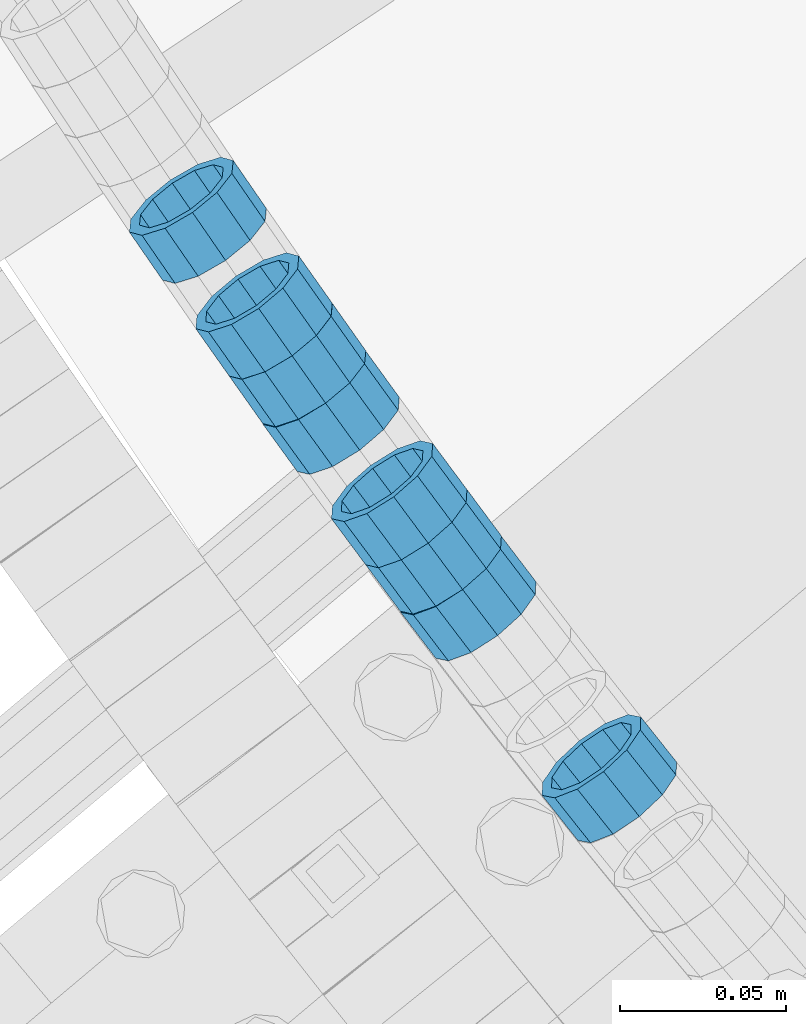
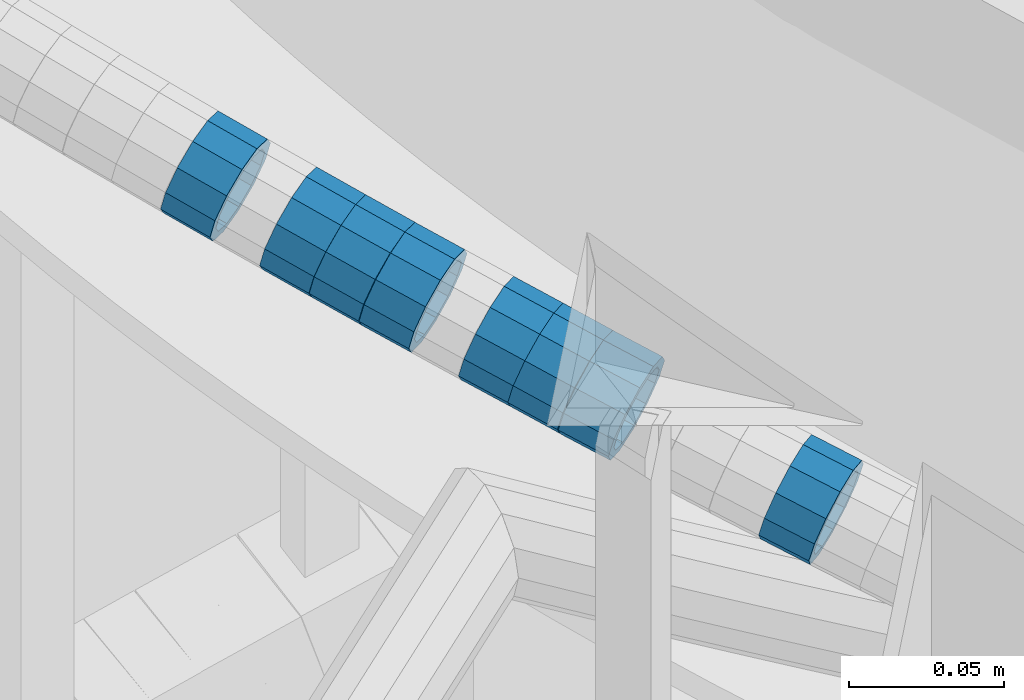
# One storey, part 652 of 975: 8 beams.
"""IFC2X3 building model written with IfcOpenShell, lengths in millimetres."""

import ifcopenshell
import ifcopenshell.guid

model = None  # the IFC model being written
_history = None  # IfcOwnerHistory: only IFC2X3 demands one
_inside = {}  # id of a spatial element -> (the spatial element, [elements in it])
_under = {}  # id of a project, library or spatial element -> (it, [spatial elements below it])
_declared = {}  # id of a project -> (the project, [libraries it declares])
_typed = {}  # id of a type object -> (the type object, [elements of that type])
_made_of = {}  # id of a material, layer set ... -> (it, [elements and type objects made of it])


def new_model(schema):
    """Start an empty IFC model of exactly this schema.

    Asked for "IFC4X3", IfcOpenShell would pick the latest addendum, in which some entities
    have other attributes; the version numbers below select the first issue.
    IFC2X3 requires an IfcOwnerHistory on every rooted entity: one is made here for all.
    """
    global model, _history
    if schema == "IFC4X3":
        model = ifcopenshell.file(schema_version=(4, 3, 0, 0))
    else:
        model = ifcopenshell.file(schema=schema)
    _inside.clear()
    _under.clear()
    _declared.clear()
    _typed.clear()
    _made_of.clear()
    _history = None
    if model.schema == "IFC2X3":
        org = make("IfcOrganization", Name="unknown")
        user = make(
            "IfcPersonAndOrganization",
            ThePerson=make("IfcPerson", FamilyName="unknown"),
            TheOrganization=org,
        )
        app = make(
            "IfcApplication",
            ApplicationDeveloper=org,
            Version="unknown",
            ApplicationFullName="unknown",
            ApplicationIdentifier="unknown",
        )
        _history = make(
            "IfcOwnerHistory",
            OwningUser=user,
            OwningApplication=app,
            ChangeAction="ADDED",
            CreationDate=0,
        )
    return model


def make(cls, **values):
    """One entity of the class cls with the attributes given. An attribute that is None is left unset."""
    return model.create_entity(
        cls, **{name: value for name, value in values.items() if value is not None}
    )


def rooted(cls, **values):
    """An entity with a GlobalId (a new one), such as an element, a storey or a relation."""
    return make(cls, GlobalId=ifcopenshell.guid.new(), OwnerHistory=_history, **values)


def si_unit(unit_type, name, prefix=None):
    """IfcSIUnit, for example si_unit("LENGTHUNIT", "METRE", prefix="MILLI")."""
    return make("IfcSIUnit", UnitType=unit_type, Prefix=prefix, Name=name)


def assignment(units):
    """IfcUnitAssignment: the units of a project."""
    return None if units is None else make("IfcUnitAssignment", Units=units)


def point(xyz):
    """IfcCartesianPoint."""
    return None if xyz is None else make("IfcCartesianPoint", Coordinates=xyz)


def direction(xyz):
    """IfcDirection."""
    return None if xyz is None else make("IfcDirection", DirectionRatios=xyz)


def frame(location, z_axis=None, x_axis=None):
    """IfcAxis2Placement3D, a coordinate frame: its origin and axes. An axis left out is left unset."""
    return make(
        "IfcAxis2Placement3D",
        Location=point(location),
        Axis=direction(z_axis),
        RefDirection=direction(x_axis),
    )


def origin_with_axes():
    """The frame at (0, 0, 0) with the z axis (0, 0, 1) and the x axis (1, 0, 0) written out."""
    return frame((0.0, 0.0, 0.0), z_axis=(0.0, 0.0, 1.0), x_axis=(1.0, 0.0, 0.0))


def place(relative_to, where):
    """IfcLocalPlacement: puts the frame where relative to a parent placement (None: the world)."""
    return make(
        "IfcLocalPlacement", PlacementRelTo=relative_to, RelativePlacement=where
    )


def context(
    kind, dimensions, precision=None, world=None, true_north=None, identifier=None
):
    """IfcGeometricRepresentationContext, for example the 3D "Model" context."""
    return make(
        "IfcGeometricRepresentationContext",
        ContextIdentifier=identifier,
        ContextType=kind,
        CoordinateSpaceDimension=dimensions,
        Precision=precision,
        WorldCoordinateSystem=world,
        TrueNorth=true_north,
    )


def subcontext(parent, identifier, kind, view, scale=None):
    """IfcGeometricRepresentationSubContext, for example "Body" below "Model"."""
    return make(
        "IfcGeometricRepresentationSubContext",
        ContextIdentifier=identifier,
        ContextType=kind,
        ParentContext=parent,
        TargetScale=scale,
        TargetView=view,
    )


def project(units=None, contexts=None):
    """IfcProject with its units and contexts."""
    return rooted(
        "IfcProject",
        Name="project",
        RepresentationContexts=contexts,
        UnitsInContext=assignment(units),
    )


def spatial(cls, under=None, at=None, **own):
    """A site, building, storey or space (cls), placed at a placement, below another one or the project."""
    s = rooted(cls, ObjectPlacement=at, **own)
    if under is not None:
        _under.setdefault(under.id(), (under, []))[1].append(s)
    return s


def faces_of(points, faces, orient=None, outer=None):
    """IfcFace entities. A face is a list of loops; a loop is a list of indices into points, from 0.

    orient and outer hold one flag for each loop. By default every Orientation is true, the
    first loop of a face is its IfcFaceOuterBound and the others are IfcFaceBound.
    """
    made = []
    for i, loops in enumerate(faces):
        bounds = []
        for j, loop in enumerate(loops):
            is_outer = j == 0 if outer is None else outer[i][j]
            bounds.append(
                make(
                    "IfcFaceOuterBound" if is_outer else "IfcFaceBound",
                    Bound=make("IfcPolyLoop", Polygon=[points[k] for k in loop]),
                    Orientation=True if orient is None else orient[i][j],
                )
            )
        made.append(make("IfcFace", Bounds=bounds))
    return made


def faceted_brep(points, faces, orient=None, outer=None, voids=None):
    """IfcFacetedBrep: a solid bounded by flat faces; with voids (closed shells), ...WithVoids."""
    shared = [point(p) for p in points]
    hull = make("IfcClosedShell", CfsFaces=faces_of(shared, faces, orient, outer))
    if voids is None:
        return make("IfcFacetedBrep", Outer=hull)
    return make(
        "IfcFacetedBrepWithVoids",
        Outer=hull,
        Voids=[
            make(cls, CfsFaces=faces_of(shared, fs, o, b)) for cls, fs, o, b in voids
        ],
    )


def shape(context_of_items, identifier, shape_type, items):
    """IfcShapeRepresentation: the items that make up one representation, for example the "Body"."""
    return make(
        "IfcShapeRepresentation",
        ContextOfItems=context_of_items,
        RepresentationIdentifier=identifier,
        RepresentationType=shape_type,
        Items=items,
    )


def material(Name=None, Category=None):
    """IfcMaterial."""
    return make("IfcMaterial", Name=Name, Category=Category)


def made_of(thing, what):
    """Note that an element or type object is made of a material, layer set ...; save() writes the relation."""
    if what is not None:
        _made_of.setdefault(what.id(), (what, []))[1].append(thing)
    return thing


def type_object(cls, material=None, **own):
    """A type object (cls), such as IfcWallType, which elements share."""
    return made_of(rooted(cls, **own), material)


def element(
    cls,
    number,
    at=None,
    inside=None,
    cuts=None,
    type_object=None,
    material=None,
    context=None,
    identifier="Body",
    shape_type=None,
    held_by="IfcProductDefinitionShape",
    body=None,
    shapes=None,
    **own,
):
    """One element of the class cls, such as IfcWall. Its Tag is "e" and its number.

    at: its placement. inside: the storey or other place that contains it. cuts: it is an
    opening in that element (IfcRelVoidsElement). A single representation is given by context,
    identifier, shape_type and body (its items); several are given by shapes. held_by: the class
    of the entity that holds the representations. save() writes the other relations.
    """
    e = rooted(cls, Tag="e%d" % number, ObjectPlacement=at, **own)
    if body is not None:
        shapes = [shape(context, identifier, shape_type, body)]
    if shapes is not None:
        e.Representation = make(held_by, Representations=shapes)
    if inside is not None:
        _inside.setdefault(inside.id(), (inside, []))[1].append(e)
    if cuts is not None:
        rooted(
            "IfcRelVoidsElement", RelatingBuildingElement=cuts, RelatedOpeningElement=e
        )
    if type_object is not None:
        _typed.setdefault(type_object.id(), (type_object, []))[1].append(e)
    return made_of(e, material)


def aggregate(whole, parts):
    """IfcRelAggregates: a whole, such as a stair, and the parts it consists of."""
    return rooted("IfcRelAggregates", RelatingObject=whole, RelatedObjects=parts)


def save(model, path):
    """Write the relations noted so far, then the file.

    IfcRelAggregates (storeys below a building ...), IfcRelContainedInSpatialStructure (elements
    in a storey), IfcRelDefinesByType, IfcRelAssociatesMaterial and IfcRelDeclares: one each for
    every whole, place, type object, material and project.
    """
    for whole, parts in _under.values():
        aggregate(whole, parts)
    for where, things in _inside.values():
        rooted(
            "IfcRelContainedInSpatialStructure",
            RelatedElements=things,
            RelatingStructure=where,
        )
    for kind, things in _typed.values():
        rooted("IfcRelDefinesByType", RelatedObjects=things, RelatingType=kind)
    for what, things in _made_of.values():
        rooted("IfcRelAssociatesMaterial", RelatedObjects=things, RelatingMaterial=what)
    for by, libraries in _declared.values():
        rooted("IfcRelDeclares", RelatingContext=by, RelatedDefinitions=libraries)
    model.write(path)


model = new_model("IFC2X3")

# Units and contexts
model_context = context("Model", 3, precision=1e-05, world=origin_with_axes())
body_context = subcontext(model_context, "Body", "Model", "MODEL_VIEW")
ifc_project = project(units=[si_unit("LENGTHUNIT", "METRE", prefix="MILLI"), si_unit("AREAUNIT", "SQUARE_METRE"), si_unit("VOLUMEUNIT", "CUBIC_METRE"), si_unit("MASSUNIT", "GRAM", prefix="KILO"), si_unit("TIMEUNIT", "SECOND"), si_unit("PLANEANGLEUNIT", "RADIAN"), si_unit("SOLIDANGLEUNIT", "STERADIAN"), si_unit("THERMODYNAMICTEMPERATUREUNIT", "DEGREE_CELSIUS"), si_unit("LUMINOUSINTENSITYUNIT", "LUMEN")], contexts=[model_context])

# Site, building, storey
site_placement = place(None, origin_with_axes())
site = spatial("IfcSite", under=ifc_project, at=site_placement, CompositionType="ELEMENT")
building_placement = place(site_placement, origin_with_axes())
building = spatial("IfcBuilding", under=site, at=building_placement, Name="Undefined", CompositionType="ELEMENT")
storey_placement = place(building_placement, origin_with_axes())
storey = spatial("IfcBuildingStorey", under=building, at=storey_placement, Name="Undefined", CompositionType="ELEMENT", Elevation=0.0)

# Beams
ifc_material = material()
beam_type = type_object("IfcBeamType", PredefinedType="NOTDEFINED")
beam_1_placement = place(storey_placement, frame((32456.294236142, 1797.82461929317, 5082.3858994355), z_axis=(0.81680953347501, 0.576907432803857, 4.64478944195434e-11), x_axis=(0.548564792050546, -0.776680844071533, -0.309586071028515)))
element("IfcBeam", 1, at=beam_1_placement, inside=storey, type_object=beam_type, material=ifc_material, Name="WALL", context=body_context, shape_type="Brep", body=[
    faceted_brep([(-2.1246523829177e-07, -15.367000000002, 0.0), (-1.83998054126278e-07, -13.3082123799541, 7.68350000000009), (18.4143965418989, -13.3082123799722, 7.68350000004284), (18.4143965419134, -15.3670000000257, 5.82076609134674e-11), (-1.06232619145885e-07, -7.68349999999919, 13.3082123799559), (18.4143965418734, -7.68350000000646, 13.3082123799759), (-3.63797880709171e-12, 3.63797880709171e-12, 15.3670000000002), (18.414396541848, 3.63797880709171e-12, 15.3669999999984), (1.06225343188271e-07, 7.68350000000646, 13.3082123799559), (18.4143965418334, 7.6835000000101, 13.3082123799395), (1.8399441614747e-07, 13.308212379965, 7.68350000000009), (18.4143965418261, 13.3082123799686, 7.68349999997736), (2.12461600312963e-07, 15.3670000000093, 0.0), (18.4143965418334, 15.3670000000093, -1.81898940354586e-11), (1.8399441614747e-07, 13.308212379965, -7.68350000000009), (18.4143965418552, 13.3082123799577, -7.68349999999919), (1.06225343188271e-07, 7.68350000000646, -13.3082123799559), (18.4143965418734, 7.68349999999191, -13.3082123799322), (-3.63797880709171e-12, 3.63797880709171e-12, -15.3670000000002), (18.4143965418989, -2.00088834390044e-11, -15.3669999999584), (-1.06232619145885e-07, -7.68349999999919, -13.3082123799559), (18.4143965419134, -7.68350000002829, -13.3082123798958), (-1.83998054126278e-07, -13.3082123799541, -7.68350000000009), (18.4143965419207, -13.3082123799832, -7.6834999999337), (-2.63386027654633e-07, -19.0500000000029, 0.0), (-2.28097633225843e-07, -16.4977839420972, -9.52499999999964), (18.4143965419316, -16.4977839421263, -9.5249999999287), (18.4143965419207, -19.0500000000284, 6.54836185276508e-11), (-1.31691194837913e-07, -9.52500000000146, -16.4977839420935), (18.4143965419207, -9.52500000003056, -16.497783942028), (-3.63797880709171e-12, 3.63797880709171e-12, -19.0500000000002), (18.4143965419025, -2.18278728425503e-11, -19.049999999952), (1.31687556859106e-07, 9.52500000000509, -16.4977839420935), (18.4143965418771, 9.52499999999054, -16.4977839420717), (2.28097633225843e-07, 16.4977839421044, -9.52499999999964), (18.414396541848, 16.4977839420972, -9.52500000000146), (2.63382389675826e-07, 19.0500000000138, 0.0), (18.4143965418298, 19.050000000012, -2.18278728425503e-11), (2.28097633225843e-07, 16.4977839421044, 9.52499999999964), (18.4143965418225, 16.4977839421117, 9.52499999997235), (1.31687556859106e-07, 9.52500000000509, 16.4977839420935), (18.4143965418225, 9.52500000001601, 16.4977839420681), (-3.63797880709171e-12, 3.63797880709171e-12, 19.0500000000002), (18.4143965418443, 7.27595761418343e-12, 19.0499999999956), (-1.31691194837913e-07, -9.52500000000146, 16.4977839420935), (18.4143965418734, -9.52500000000691, 16.4977839421153), (-2.28097633225843e-07, -16.4977839420972, 9.52499999999964), (18.4143965418989, -16.4977839421117, 9.52500000004511)], [[[0, 1, 2, 3]], [[1, 4, 5, 2]], [[4, 6, 7, 5]], [[6, 8, 9, 7]], [[8, 10, 11, 9]], [[10, 12, 13, 11]], [[12, 14, 15, 13]], [[14, 16, 17, 15]], [[16, 18, 19, 17]], [[18, 20, 21, 19]], [[20, 22, 23, 21]], [[22, 0, 3, 23]], [[24, 25, 26, 27]], [[25, 28, 29, 26]], [[28, 30, 31, 29]], [[30, 32, 33, 31]], [[32, 34, 35, 33]], [[34, 36, 37, 35]], [[36, 38, 39, 37]], [[38, 40, 41, 39]], [[40, 42, 43, 41]], [[42, 44, 45, 43]], [[44, 46, 47, 45]], [[46, 24, 27, 47]], [[29, 31, 33, 35, 37, 39, 41, 43, 45, 47, 27, 26], [5, 7, 9, 11, 13, 15, 17, 19, 21, 23, 3, 2]], [[46, 44, 42, 40, 38, 36, 34, 32, 30, 28, 25, 24], [22, 20, 18, 16, 14, 12, 10, 8, 6, 4, 1, 0]]]),
])
beam_2_placement = place(storey_placement, frame((32446.1404028189, 1812.2008387506, 5088.21654689382), z_axis=(0.81680953347501, 0.576907432803857, 4.64478944195434e-11), x_axis=(0.547636668824332, -0.775366768751297, -0.314484423899121)))
element("IfcBeam", 2, at=beam_2_placement, inside=storey, type_object=beam_type, material=ifc_material, Name="WALL", context=body_context, shape_type="Brep", body=[
    faceted_brep([(-2.1246523829177e-07, -15.367000000002, 0.0), (-1.83998054126278e-07, -13.3082123799541, 7.68350000000009), (18.4442402933746, -13.3082123799431, 7.68349999998463), (18.4442402933928, -15.3669999999893, -3.63797880709171e-12), (-1.06232619145885e-07, -7.68349999999919, 13.3082123799559), (18.4442402933564, -7.68349999998281, 13.308212379925), (-3.63797880709171e-12, 3.63797880709171e-12, 15.3670000000002), (18.4442402933455, 1.81898940354586e-11, 15.3669999999584), (1.06225343188271e-07, 7.68350000000646, 13.3082123799559), (18.4442402933419, 7.68350000001737, 13.3082123799104), (1.8399441614747e-07, 13.308212379965, 7.68350000000009), (18.4442402933528, 13.3082123799722, 7.68349999996281), (2.12461600312963e-07, 15.3670000000093, 0.0), (18.4442402933637, 15.3670000000129, -2.5465851649642e-11), (1.8399441614747e-07, 13.308212379965, -7.68350000000009), (18.4442402933855, 13.308212379965, -7.6835000000101), (1.06225343188271e-07, 7.68350000000646, -13.3082123799559), (18.4442402934037, 7.68350000000646, -13.3082123799541), (-3.63797880709171e-12, 3.63797880709171e-12, -15.3670000000002), (18.444240293411, 5.45696821063757e-12, -15.3669999999911), (-1.06232619145885e-07, -7.68349999999919, -13.3082123799559), (18.4442402934146, -7.68349999999373, -13.3082123799431), (-1.83998054126278e-07, -13.3082123799541, -7.68350000000009), (18.4442402934037, -13.3082123799468, -7.68349999999191), (-2.63386027654633e-07, -19.0500000000029, 0.0), (-2.28097633225843e-07, -16.4977839420972, -9.52499999999964), (18.444240293411, -16.4977839420862, -9.5249999999869), (18.4442402933964, -19.0499999999902, 0.0), (-1.31691194837913e-07, -9.52500000000146, -16.4977839420935), (18.4442402934219, -9.524999999996, -16.4977839420717), (-3.63797880709171e-12, 3.63797880709171e-12, -19.0500000000002), (18.4442402934183, 3.63797880709171e-12, -19.0499999999847), (1.31687556859106e-07, 9.52500000000509, -16.4977839420935), (18.4442402934073, 9.52500000000509, -16.4977839420899), (2.28097633225843e-07, 16.4977839421044, -9.52499999999964), (18.4442402933855, 16.4977839421008, -9.52500000001601), (2.63382389675826e-07, 19.0500000000138, 0.0), (18.4442402933637, 19.0500000000138, -2.91038304567337e-11), (2.28097633225843e-07, 16.4977839421044, 9.52499999999964), (18.4442402933419, 16.4977839421117, 9.52499999995052), (1.31687556859106e-07, 9.52500000000509, 16.4977839420935), (18.4442402933346, 9.52500000001965, 16.4977839420426), (-3.63797880709171e-12, 3.63797880709171e-12, 19.0500000000002), (18.4442402933346, 2.00088834390044e-11, 19.0499999999483), (-1.31691194837913e-07, -9.52500000000146, 16.4977839420935), (18.4442402933528, -9.52499999998145, 16.4977839420571), (-2.28097633225843e-07, -16.4977839420972, 9.52499999999964), (18.4442402933746, -16.497783942079, 9.52499999998327)], [[[0, 1, 2, 3]], [[1, 4, 5, 2]], [[4, 6, 7, 5]], [[6, 8, 9, 7]], [[8, 10, 11, 9]], [[10, 12, 13, 11]], [[12, 14, 15, 13]], [[14, 16, 17, 15]], [[16, 18, 19, 17]], [[18, 20, 21, 19]], [[20, 22, 23, 21]], [[22, 0, 3, 23]], [[24, 25, 26, 27]], [[25, 28, 29, 26]], [[28, 30, 31, 29]], [[30, 32, 33, 31]], [[32, 34, 35, 33]], [[34, 36, 37, 35]], [[36, 38, 39, 37]], [[38, 40, 41, 39]], [[40, 42, 43, 41]], [[42, 44, 45, 43]], [[44, 46, 47, 45]], [[46, 24, 27, 47]], [[29, 31, 33, 35, 37, 39, 41, 43, 45, 47, 27, 26], [5, 7, 9, 11, 13, 15, 17, 19, 21, 23, 3, 2]], [[46, 44, 42, 40, 38, 36, 34, 32, 30, 28, 25, 24], [22, 20, 18, 16, 14, 12, 10, 8, 6, 4, 1, 0]]]),
])
beam_3_placement = place(storey_placement, frame((32426.2139619916, 1841.21223664448, 5099.70572860158), z_axis=(0.823212785893848, 0.567732955834774, -2.45145201915875e-11), x_axis=(0.539250090044497, -0.781912631064559, -0.312765052025797)))
element("IfcBeam", 3, at=beam_3_placement, inside=storey, type_object=beam_type, material=ifc_material, Name="WALL", context=body_context, shape_type="Brep", body=[
    faceted_brep([(-2.1246523829177e-07, -15.367000000002, 0.0), (-1.83998054126278e-07, -13.3082123799541, 7.68350000000009), (18.5442713526427, -13.3082123799486, 7.68349999999555), (18.544271352639, -15.3669999999893, -1.81898940354586e-12), (-1.06232619145885e-07, -7.68349999999919, 13.3082123799559), (18.5442713526427, -7.68349999999373, 13.3082123799541), (-3.63797880709171e-12, 3.63797880709171e-12, 15.3670000000002), (18.5442713526354, 5.45696821063757e-12, 15.3669999999947), (1.06225343188271e-07, 7.68350000000646, 13.3082123799559), (18.5442713526245, 7.68350000001192, 13.3082123799468), (1.8399441614747e-07, 13.308212379965, 7.68350000000009), (18.5442713526172, 13.3082123799704, 7.68349999998827), (2.12461600312963e-07, 15.3670000000093, 0.0), (18.5442713526027, 15.3670000000202, -1.45519152283669e-11), (1.8399441614747e-07, 13.308212379965, -7.68350000000009), (18.5442713526027, 13.3082123799759, -7.68350000001556), (1.06225343188271e-07, 7.68350000000646, -13.3082123799559), (18.5442713526027, 7.68350000002283, -13.3082123799686), (-3.63797880709171e-12, 3.63797880709171e-12, -15.3670000000002), (18.5442713526063, 2.18278728425503e-11, -15.3670000000129), (-1.06232619145885e-07, -7.68349999999919, -13.3082123799559), (18.5442713526209, -7.68349999998281, -13.3082123799632), (-1.83998054126278e-07, -13.3082123799541, -7.68350000000009), (18.5442713526318, -13.3082123799395, -7.68350000000646), (-2.63386027654633e-07, -19.0500000000029, 0.0), (-2.28097633225843e-07, -16.4977839420972, -9.52499999999964), (18.5442713526354, -16.4977839420808, -9.52500000000691), (18.5442713526427, -19.0499999999902, -1.81898940354586e-12), (-1.31691194837913e-07, -9.52500000000146, -16.4977839420935), (18.5442713526245, -9.52499999997963, -16.4977839421044), (-3.63797880709171e-12, 3.63797880709171e-12, -19.0500000000002), (18.5442713526099, 2.36468622460961e-11, -19.0500000000138), (1.31687556859106e-07, 9.52500000000509, -16.4977839420935), (18.544271352599, 9.5250000000251, -16.4977839421081), (2.28097633225843e-07, 16.4977839421044, -9.52499999999964), (18.5442713525917, 16.4977839421172, -9.52500000001601), (2.63382389675826e-07, 19.0500000000138, 0.0), (18.544271352599, 19.0500000000211, -1.45519152283669e-11), (2.28097633225843e-07, 16.4977839421044, 9.52499999999964), (18.5442713526136, 16.4977839421099, 9.52499999998872), (1.31687556859106e-07, 9.52500000000509, 16.4977839420935), (18.5442713526281, 9.52500000000873, 16.4977839420862), (-3.63797880709171e-12, 3.63797880709171e-12, 19.0500000000002), (18.5442713526427, 3.63797880709171e-12, 19.0499999999975), (-1.31691194837913e-07, -9.52500000000146, 16.4977839420935), (18.54427135265, -9.524999999996, 16.4977839420935), (-2.28097633225843e-07, -16.4977839420972, 9.52499999999964), (18.54427135265, -16.4977839420899, 9.52499999999964)], [[[0, 1, 2, 3]], [[1, 4, 5, 2]], [[4, 6, 7, 5]], [[6, 8, 9, 7]], [[8, 10, 11, 9]], [[10, 12, 13, 11]], [[12, 14, 15, 13]], [[14, 16, 17, 15]], [[16, 18, 19, 17]], [[18, 20, 21, 19]], [[20, 22, 23, 21]], [[22, 0, 3, 23]], [[24, 25, 26, 27]], [[25, 28, 29, 26]], [[28, 30, 31, 29]], [[30, 32, 33, 31]], [[32, 34, 35, 33]], [[34, 36, 37, 35]], [[36, 38, 39, 37]], [[38, 40, 41, 39]], [[40, 42, 43, 41]], [[42, 44, 45, 43]], [[44, 46, 47, 45]], [[46, 24, 27, 47]], [[29, 31, 33, 35, 37, 39, 41, 43, 45, 47, 27, 26], [5, 7, 9, 11, 13, 15, 17, 19, 21, 23, 3, 2]], [[46, 44, 42, 40, 38, 36, 34, 32, 30, 28, 25, 24], [22, 20, 18, 16, 14, 12, 10, 8, 6, 4, 1, 0]]]),
])
beam_4_placement = place(storey_placement, frame((32507.6154561329, 1727.10343788765, 5053.78854079074), z_axis=(0.795169005057413, 0.606387873721107, -8.36653271107936e-11), x_axis=(0.576512822828125, -0.755993230774699, -0.310011612907612)))
element("IfcBeam", 4, at=beam_4_placement, inside=storey, type_object=beam_type, material=ifc_material, Name="WALL", context=body_context, shape_type="Brep", body=[
    faceted_brep([(-2.1246523829177e-07, -15.367000000002, 0.0), (-1.83998054126278e-07, -13.3082123799541, 7.68350000000009), (18.3929334256754, -13.3082123799595, 7.68350000001374), (18.39293342569, -15.3670000000111, 3.27418092638254e-11), (-1.06232619145885e-07, -7.68349999999919, 13.3082123799559), (18.3929334256572, -7.68349999999373, 13.3082123799504), (-3.63797880709171e-12, 3.63797880709171e-12, 15.3670000000002), (18.3929334256391, 1.2732925824821e-11, 15.3669999999802), (1.06225343188271e-07, 7.68350000000646, 13.3082123799559), (18.3929334256318, 7.68350000001556, 13.3082123799286), (1.8399441614747e-07, 13.308212379965, 7.68350000000009), (18.3929334256391, 13.3082123799704, 7.68349999997736), (2.12461600312963e-07, 15.3670000000093, 0.0), (18.3929334256536, 15.3670000000111, -1.09139364212751e-11), (1.8399441614747e-07, 13.308212379965, -7.68350000000009), (18.3929334256682, 13.3082123799595, -7.68349999999191), (1.06225343188271e-07, 7.68350000000646, -13.3082123799559), (18.3929334256864, 7.68349999999373, -13.3082123799286), (-3.63797880709171e-12, 3.63797880709171e-12, -15.3670000000002), (18.3929334257045, -1.2732925824821e-11, -15.3669999999584), (-1.06232619145885e-07, -7.68349999999919, -13.3082123799559), (18.3929334257118, -7.68350000001919, -13.3082123799068), (-1.83998054126278e-07, -13.3082123799541, -7.68350000000009), (18.3929334257082, -13.3082123799704, -7.68349999995553), (-2.63386027654633e-07, -19.0500000000029, 0.0), (-2.28097633225843e-07, -16.4977839420972, -9.52499999999964), (18.3929334257155, -16.4977839421135, -9.52499999994689), (18.3929334257009, -19.0500000000156, 3.63797880709171e-11), (-1.31691194837913e-07, -9.52500000000146, -16.4977839420935), (18.3929334257191, -9.52500000002146, -16.4977839420353), (-3.63797880709171e-12, 3.63797880709171e-12, -19.0500000000002), (18.3929334257155, -1.81898940354586e-11, -19.0499999999483), (1.31687556859106e-07, 9.52500000000509, -16.4977839420935), (18.3929334256936, 9.52499999999236, -16.4977839420608), (2.28097633225843e-07, 16.4977839421044, -9.52499999999964), (18.3929334256682, 16.4977839420953, -9.52499999999418), (2.63382389675826e-07, 19.0500000000138, 0.0), (18.3929334256391, 19.050000000012, -1.81898940354586e-11), (2.28097633225843e-07, 16.4977839421044, 9.52499999999964), (18.3929334256281, 16.4977839421117, 9.52499999996508), (1.31687556859106e-07, 9.52500000000509, 16.4977839420935), (18.3929334256245, 9.52500000001965, 16.4977839420571), (-3.63797880709171e-12, 3.63797880709171e-12, 19.0500000000002), (18.3929334256318, 1.63709046319127e-11, 19.0499999999738), (-1.31691194837913e-07, -9.52500000000146, 16.4977839420935), (18.39293342565, -9.52499999999236, 16.4977839420826), (-2.28097633225843e-07, -16.4977839420972, 9.52499999999964), (18.3929334256754, -16.497783942099, 9.52500000001601)], [[[0, 1, 2, 3]], [[1, 4, 5, 2]], [[4, 6, 7, 5]], [[6, 8, 9, 7]], [[8, 10, 11, 9]], [[10, 12, 13, 11]], [[12, 14, 15, 13]], [[14, 16, 17, 15]], [[16, 18, 19, 17]], [[18, 20, 21, 19]], [[20, 22, 23, 21]], [[22, 0, 3, 23]], [[24, 25, 26, 27]], [[25, 28, 29, 26]], [[28, 30, 31, 29]], [[30, 32, 33, 31]], [[32, 34, 35, 33]], [[34, 36, 37, 35]], [[36, 38, 39, 37]], [[38, 40, 41, 39]], [[40, 42, 43, 41]], [[42, 44, 45, 43]], [[44, 46, 47, 45]], [[46, 24, 27, 47]], [[29, 31, 33, 35, 37, 39, 41, 43, 45, 47, 27, 26], [5, 7, 9, 11, 13, 15, 17, 19, 21, 23, 3, 2]], [[46, 44, 42, 40, 38, 36, 34, 32, 30, 28, 25, 24], [22, 20, 18, 16, 14, 12, 10, 8, 6, 4, 1, 0]]]),
])
beam_5_placement = place(storey_placement, frame((32486.8675232032, 1755.15809039552, 5065.2925740051), z_axis=(0.802743847607593, 0.59632400180452, 2.87554030364846e-10), x_axis=(0.566818518071502, -0.763024927096222, -0.310660149039156)))
element("IfcBeam", 5, at=beam_5_placement, inside=storey, type_object=beam_type, material=ifc_material, Name="WALL", context=body_context, shape_type="Brep", body=[
    faceted_brep([(-2.1246523829177e-07, -15.367000000002, 0.0), (-1.83998054126278e-07, -13.3082123799541, 7.68350000000009), (18.3491144200598, -13.3082123799504, 7.68349999999373), (18.3491144200925, -15.3670000000038, 7.27595761418343e-12), (-1.06232619145885e-07, -7.68349999999919, 13.3082123799559), (18.3491144200307, -7.68349999998463, 13.3082123799359), (-3.63797880709171e-12, 3.63797880709171e-12, 15.3670000000002), (18.3491144200016, 2.5465851649642e-11, 15.3669999999674), (1.06225343188271e-07, 7.68350000000646, 13.3082123799559), (18.3491144199943, 7.68350000003193, 13.3082123799177), (1.8399441614747e-07, 13.308212379965, 7.68350000000009), (18.3491144199907, 13.3082123799941, 7.68349999996281), (2.12461600312963e-07, 15.3670000000093, 0.0), (18.3491144200052, 15.3670000000347, -3.09228198602796e-11), (1.8399441614747e-07, 13.308212379965, -7.68350000000009), (18.3491144200379, 13.3082123799832, -7.68350000001556), (1.06225343188271e-07, 7.68350000000646, -13.3082123799559), (18.3491144200707, 7.68350000001374, -13.3082123799577), (-3.63797880709171e-12, 3.63797880709171e-12, -15.3670000000002), (18.3491144200962, 3.63797880709171e-12, -15.3669999999911), (-1.06232619145885e-07, -7.68349999999919, -13.3082123799559), (18.3491144201143, -7.68350000000464, -13.3082123799377), (-1.83998054126278e-07, -13.3082123799541, -7.68350000000009), (18.3491144201107, -13.3082123799632, -7.68349999998645), (-2.63386027654633e-07, -19.0500000000029, 0.0), (-2.28097633225843e-07, -16.4977839420972, -9.52499999999964), (18.349114420118, -16.4977839421044, -9.52499999997963), (18.3491144201034, -19.0500000000102, 1.09139364212751e-11), (-1.31691194837913e-07, -9.52500000000146, -16.4977839420935), (18.3491144201253, -9.52500000000873, -16.4977839420717), (-3.63797880709171e-12, 3.63797880709171e-12, -19.0500000000002), (18.3491144201071, 3.63797880709171e-12, -19.0499999999865), (1.31687556859106e-07, 9.52500000000509, -16.4977839420935), (18.3491144200743, 9.52500000001601, -16.4977839420953), (2.28097633225843e-07, 16.4977839421044, -9.52499999999964), (18.3491144200416, 16.4977839421226, -9.52500000001965), (2.63382389675826e-07, 19.0500000000138, 0.0), (18.3491144199979, 19.0500000000393, -3.63797880709171e-11), (2.28097633225843e-07, 16.4977839421044, 9.52499999999964), (18.3491144199797, 16.4977839421372, 9.52499999995598), (1.31687556859106e-07, 9.52500000000509, 16.4977839420935), (18.3491144199761, 9.52500000003783, 16.497783942048), (-3.63797880709171e-12, 3.63797880709171e-12, 19.0500000000002), (18.3491144199979, 2.72848410531878e-11, 19.0499999999647), (-1.31691194837913e-07, -9.52500000000146, 16.4977839420935), (18.349114420027, -9.52499999998327, 16.4977839420735), (-2.28097633225843e-07, -16.4977839420972, 9.52499999999964), (18.3491144200671, -16.4977839420935, 9.524999999996)], [[[0, 1, 2, 3]], [[1, 4, 5, 2]], [[4, 6, 7, 5]], [[6, 8, 9, 7]], [[8, 10, 11, 9]], [[10, 12, 13, 11]], [[12, 14, 15, 13]], [[14, 16, 17, 15]], [[16, 18, 19, 17]], [[18, 20, 21, 19]], [[20, 22, 23, 21]], [[22, 0, 3, 23]], [[24, 25, 26, 27]], [[25, 28, 29, 26]], [[28, 30, 31, 29]], [[30, 32, 33, 31]], [[32, 34, 35, 33]], [[34, 36, 37, 35]], [[36, 38, 39, 37]], [[38, 40, 41, 39]], [[40, 42, 43, 41]], [[42, 44, 45, 43]], [[44, 46, 47, 45]], [[46, 24, 27, 47]], [[29, 31, 33, 35, 37, 39, 41, 43, 45, 47, 27, 26], [5, 7, 9, 11, 13, 15, 17, 19, 21, 23, 3, 2]], [[46, 44, 42, 40, 38, 36, 34, 32, 30, 28, 25, 24], [22, 20, 18, 16, 14, 12, 10, 8, 6, 4, 1, 0]]]),
])
beam_6_placement = place(storey_placement, frame((32497.2117271175, 1741.23320051093, 5059.62342257377), z_axis=(0.802743847607593, 0.59632400180452, 2.87554030364846e-10), x_axis=(0.565852862118601, -0.761725006159651, -0.315571788066149)))
element("IfcBeam", 6, at=beam_6_placement, inside=storey, type_object=beam_type, material=ifc_material, Name="WALL", context=body_context, shape_type="Brep", body=[
    faceted_brep([(-2.1246523829177e-07, -15.367000000002, 0.0), (-1.83998054126278e-07, -13.3082123799541, 7.68350000000009), (18.3831444535936, -13.3082123799741, 7.68350000002465), (18.3831444535717, -15.3670000000056, 7.27595761418343e-12), (-1.06232619145885e-07, -7.68349999999919, 13.3082123799559), (18.3831444536154, -7.68350000002283, 13.3082123799941), (-3.63797880709171e-12, 3.63797880709171e-12, 15.3670000000002), (18.3831444536409, -3.09228198602796e-11, 15.3670000000493), (1.06225343188271e-07, 7.68350000000646, 13.3082123799559), (18.3831444536554, 7.68349999996462, 13.3082123800159), (1.8399441614747e-07, 13.308212379965, 7.68350000000009), (18.3831444536554, 13.3082123799231, 7.68350000006103), (2.12461600312963e-07, 15.3670000000093, 0.0), (18.3831444536409, 15.3669999999747, 5.0931703299284e-11), (1.8399441614747e-07, 13.308212379965, -7.68350000000009), (18.3831444536154, 13.3082123799413, -7.68349999996281), (1.06225343188271e-07, 7.68350000000646, -13.3082123799559), (18.3831444535899, 7.68349999999737, -13.3082123799359), (-3.63797880709171e-12, 3.63797880709171e-12, -15.3670000000002), (18.3831444535681, 5.45696821063757e-12, -15.3669999999947), (-1.06232619145885e-07, -7.68349999999919, -13.3082123799559), (18.3831444535608, -7.68349999999737, -13.3082123799577), (-1.83998054126278e-07, -13.3082123799541, -7.68350000000009), (18.3831444535535, -13.3082123799522, -7.68350000000282), (-2.63386027654633e-07, -19.0500000000029, 0.0), (-2.28097633225843e-07, -16.4977839420972, -9.52499999999964), (18.3831444535426, -16.4977839420862, -9.52500000000873), (18.3831444535608, -19.0500000000047, 3.63797880709171e-12), (-1.31691194837913e-07, -9.52500000000146, -16.4977839420935), (18.383144453539, -9.52499999998872, -16.4977839421081), (-3.63797880709171e-12, 3.63797880709171e-12, -19.0500000000002), (18.3831444535572, 9.09494701772928e-12, -19.0500000000029), (1.31687556859106e-07, 9.52500000000509, -16.4977839420935), (18.3831444535863, 9.52499999999964, -16.497783942079), (2.28097633225843e-07, 16.4977839421044, -9.52499999999964), (18.383144453619, 16.4977839420808, -9.52499999996508), (2.63382389675826e-07, 19.0500000000138, 0.0), (18.3831444536481, 19.049999999972, 5.45696821063757e-11), (2.28097633225843e-07, 16.4977839421044, 9.52499999999964), (18.3831444536663, 16.4977839420571, 9.52500000006694), (1.31687556859106e-07, 9.52500000000509, 16.4977839420935), (18.3831444536663, 9.52499999996144, 16.4977839421626), (-3.63797880709171e-12, 3.63797880709171e-12, 19.0500000000002), (18.3831444536518, -3.45607986673713e-11, 19.0500000000575), (-1.31691194837913e-07, -9.52500000000146, 16.4977839420935), (18.3831444536263, -9.52500000002874, 16.4977839421372), (-2.28097633225843e-07, -16.4977839420972, 9.52499999999964), (18.3831444535863, -16.4977839421099, 9.52500000001965)], [[[0, 1, 2, 3]], [[1, 4, 5, 2]], [[4, 6, 7, 5]], [[6, 8, 9, 7]], [[8, 10, 11, 9]], [[10, 12, 13, 11]], [[12, 14, 15, 13]], [[14, 16, 17, 15]], [[16, 18, 19, 17]], [[18, 20, 21, 19]], [[20, 22, 23, 21]], [[22, 0, 3, 23]], [[24, 25, 26, 27]], [[25, 28, 29, 26]], [[28, 30, 31, 29]], [[30, 32, 33, 31]], [[32, 34, 35, 33]], [[34, 36, 37, 35]], [[36, 38, 39, 37]], [[38, 40, 41, 39]], [[40, 42, 43, 41]], [[42, 44, 45, 43]], [[44, 46, 47, 45]], [[46, 24, 27, 47]], [[29, 31, 33, 35, 37, 39, 41, 43, 45, 47, 27, 26], [5, 7, 9, 11, 13, 15, 17, 19, 21, 23, 3, 2]], [[46, 44, 42, 40, 38, 36, 34, 32, 30, 28, 25, 24], [22, 20, 18, 16, 14, 12, 10, 8, 6, 4, 1, 0]]]),
])
beam_7_placement = place(storey_placement, frame((32466.3400688153, 1783.47272537981, 5076.68242879456), z_axis=(0.809474973106366, 0.587154381670143, -1.07052983366884e-10), x_axis=(0.558415294068641, -0.769854095094567, -0.309025940037981)))
element("IfcBeam", 7, at=beam_7_placement, inside=storey, type_object=beam_type, material=ifc_material, Name="WALL", context=body_context, shape_type="Brep", body=[
    faceted_brep([(-2.1246523829177e-07, -15.367000000002, 0.0), (-1.83998054126278e-07, -13.3082123799541, 7.68350000000009), (18.4537259110693, -13.3082123799595, 7.68349999998827), (18.453725911073, -15.3670000000038, 0.0), (-1.06232619145885e-07, -7.68349999999919, 13.3082123799559), (18.4537259110621, -7.683500000001, 13.3082123799431), (-3.63797880709171e-12, 3.63797880709171e-12, 15.3670000000002), (18.453725911073, -1.81898940354586e-12, 15.3669999999911), (1.06225343188271e-07, 7.68350000000646, 13.3082123799559), (18.4537259110839, 7.68349999999737, 13.3082123799504), (1.8399441614747e-07, 13.308212379965, 7.68350000000009), (18.4537259110948, 13.3082123799522, 7.68350000000646), (2.12461600312963e-07, 15.3670000000093, 0.0), (18.4537259111057, 15.3669999999947, 1.09139364212751e-11), (1.8399441614747e-07, 13.308212379965, -7.68350000000009), (18.4537259111203, 13.3082123799486, -7.68349999997372), (1.06225343188271e-07, 7.68350000000646, -13.3082123799559), (18.4537259111166, 7.68349999999373, -13.3082123799322), (-3.63797880709171e-12, 3.63797880709171e-12, -15.3670000000002), (18.4537259111094, -5.45696821063757e-12, -15.3669999999765), (-1.06232619145885e-07, -7.68349999999919, -13.3082123799559), (18.4537259111057, -7.68350000000646, -13.3082123799395), (-1.83998054126278e-07, -13.3082123799541, -7.68350000000009), (18.4537259110912, -13.3082123799595, -7.68349999999555), (-2.63386027654633e-07, -19.0500000000029, 0.0), (-2.28097633225843e-07, -16.4977839420972, -9.52499999999964), (18.4537259110839, -16.497783942099, -9.52499999999418), (18.453725911073, -19.0500000000029, -7.27595761418343e-12), (-1.31691194837913e-07, -9.52500000000146, -16.4977839420935), (18.4537259111057, -9.52500000000509, -16.497783942079), (-3.63797880709171e-12, 3.63797880709171e-12, -19.0500000000002), (18.4537259111166, -7.27595761418343e-12, -19.0499999999702), (1.31687556859106e-07, 9.52500000000509, -16.4977839420935), (18.4537259111275, 9.52499999999236, -16.4977839420608), (2.28097633225843e-07, 16.4977839421044, -9.52499999999964), (18.4537259111239, 16.4977839420881, -9.52499999997235), (2.63382389675826e-07, 19.0500000000138, 0.0), (18.4537259111057, 19.0499999999938, 1.81898940354586e-11), (2.28097633225843e-07, 16.4977839421044, 9.52499999999964), (18.4537259110948, 16.4977839420917, 9.52500000000509), (1.31687556859106e-07, 9.52500000000509, 16.4977839420935), (18.4537259110803, 9.52499999999782, 16.4977839420862), (-3.63797880709171e-12, 3.63797880709171e-12, 19.0500000000002), (18.4537259110621, -1.81898940354586e-12, 19.0499999999811), (-1.31691194837913e-07, -9.52500000000146, 16.4977839420935), (18.4537259110584, -9.52500000000146, 16.4977839420753), (-2.28097633225843e-07, -16.4977839420972, 9.52499999999964), (18.4537259110621, -16.4977839420953, 9.52499999998327)], [[[0, 1, 2, 3]], [[1, 4, 5, 2]], [[4, 6, 7, 5]], [[6, 8, 9, 7]], [[8, 10, 11, 9]], [[10, 12, 13, 11]], [[12, 14, 15, 13]], [[14, 16, 17, 15]], [[16, 18, 19, 17]], [[18, 20, 21, 19]], [[20, 22, 23, 21]], [[22, 0, 3, 23]], [[24, 25, 26, 27]], [[25, 28, 29, 26]], [[28, 30, 31, 29]], [[30, 32, 33, 31]], [[32, 34, 35, 33]], [[34, 36, 37, 35]], [[36, 38, 39, 37]], [[38, 40, 41, 39]], [[40, 42, 43, 41]], [[42, 44, 45, 43]], [[44, 46, 47, 45]], [[46, 24, 27, 47]], [[29, 31, 33, 35, 37, 39, 41, 43, 45, 47, 27, 26], [5, 7, 9, 11, 13, 15, 17, 19, 21, 23, 3, 2]], [[46, 44, 42, 40, 38, 36, 34, 32, 30, 28, 25, 24], [22, 20, 18, 16, 14, 12, 10, 8, 6, 4, 1, 0]]]),
])
beam_8_placement = place(storey_placement, frame((32550.1021945684, 1672.05962313435, 5031.09998607848), z_axis=(0.783110847188518, 0.621882143991675, -4.0618033381179e-11), x_axis=(0.59087010501273, -0.744058650016086, -0.311848111006761)))
element("IfcBeam", 8, at=beam_8_placement, inside=storey, type_object=beam_type, material=ifc_material, Name="WALL", context=body_context, shape_type="Brep", body=[
    faceted_brep([(-2.1246523829177e-07, -15.367000000002, 0.0), (-1.83998054126278e-07, -13.3082123799541, 7.68350000000009), (18.2781290071252, -13.308212379965, 7.68350000002829), (18.2781290071325, -15.3670000000129, 4.00177668780088e-11), (-1.06232619145885e-07, -7.68349999999919, 13.3082123799559), (18.278129007118, -7.68350000000282, 13.3082123799686), (-3.63797880709171e-12, 3.63797880709171e-12, 15.3670000000002), (18.2781290071071, 3.63797880709171e-12, 15.367000000002), (1.06225343188271e-07, 7.68350000000646, 13.3082123799559), (18.2781290071034, 7.68350000000828, 13.3082123799468), (1.8399441614747e-07, 13.308212379965, 7.68350000000009), (18.2781290070998, 13.3082123799632, 7.68349999999191), (2.12461600312963e-07, 15.3670000000093, 0.0), (18.2781290070998, 15.3670000000056, -7.27595761418343e-12), (1.8399441614747e-07, 13.308212379965, -7.68350000000009), (18.2781290071034, 13.3082123799559, -7.68349999999555), (1.06225343188271e-07, 7.68350000000646, -13.3082123799559), (18.2781290071143, 7.68349999999373, -13.3082123799395), (-3.63797880709171e-12, 3.63797880709171e-12, -15.3670000000002), (18.2781290071252, -1.2732925824821e-11, -15.3669999999693), (-1.06232619145885e-07, -7.68349999999919, -13.3082123799559), (18.2781290071325, -7.68350000001556, -13.3082123799177), (-1.83998054126278e-07, -13.3082123799541, -7.68350000000009), (18.2781290071325, -13.3082123799722, -7.68349999995553), (-2.63386027654633e-07, -19.0500000000029, 0.0), (-2.28097633225843e-07, -16.4977839420972, -9.52499999999964), (18.2781290071398, -16.4977839421117, -9.52499999995052), (18.2781290071325, -19.0500000000156, 4.36557456851006e-11), (-1.31691194837913e-07, -9.52500000000146, -16.4977839420935), (18.2781290071325, -9.52500000001783, -16.4977839420462), (-3.63797880709171e-12, 3.63797880709171e-12, -19.0500000000002), (18.2781290071289, -1.2732925824821e-11, -19.0499999999629), (1.31687556859106e-07, 9.52500000000509, -16.4977839420935), (18.2781290071143, 9.52499999999418, -16.4977839420753), (2.28097633225843e-07, 16.4977839421044, -9.52499999999964), (18.2781290071071, 16.4977839420935, -9.52499999999782), (2.63382389675826e-07, 19.0500000000138, 0.0), (18.2781290070961, 19.0500000000084, -1.09139364212751e-11), (2.28097633225843e-07, 16.4977839421044, 9.52499999999964), (18.2781290070925, 16.4977839421044, 9.52499999998327), (1.31687556859106e-07, 9.52500000000509, 16.4977839420935), (18.2781290070961, 9.52500000001055, 16.497783942079), (-3.63797880709171e-12, 3.63797880709171e-12, 19.0500000000002), (18.2781290071034, 5.45696821063757e-12, 19.0499999999993), (-1.31691194837913e-07, -9.52500000000146, 16.4977839420935), (18.278129007118, -9.52500000000146, 16.4977839421081), (-2.28097633225843e-07, -16.4977839420972, 9.52499999999964), (18.2781290071252, -16.4977839421026, 9.52500000003056)], [[[0, 1, 2, 3]], [[1, 4, 5, 2]], [[4, 6, 7, 5]], [[6, 8, 9, 7]], [[8, 10, 11, 9]], [[10, 12, 13, 11]], [[12, 14, 15, 13]], [[14, 16, 17, 15]], [[16, 18, 19, 17]], [[18, 20, 21, 19]], [[20, 22, 23, 21]], [[22, 0, 3, 23]], [[24, 25, 26, 27]], [[25, 28, 29, 26]], [[28, 30, 31, 29]], [[30, 32, 33, 31]], [[32, 34, 35, 33]], [[34, 36, 37, 35]], [[36, 38, 39, 37]], [[38, 40, 41, 39]], [[40, 42, 43, 41]], [[42, 44, 45, 43]], [[44, 46, 47, 45]], [[46, 24, 27, 47]], [[29, 31, 33, 35, 37, 39, 41, 43, 45, 47, 27, 26], [5, 7, 9, 11, 13, 15, 17, 19, 21, 23, 3, 2]], [[46, 44, 42, 40, 38, 36, 34, 32, 30, 28, 25, 24], [22, 20, 18, 16, 14, 12, 10, 8, 6, 4, 1, 0]]]),
])

save(model, "model.ifc")
